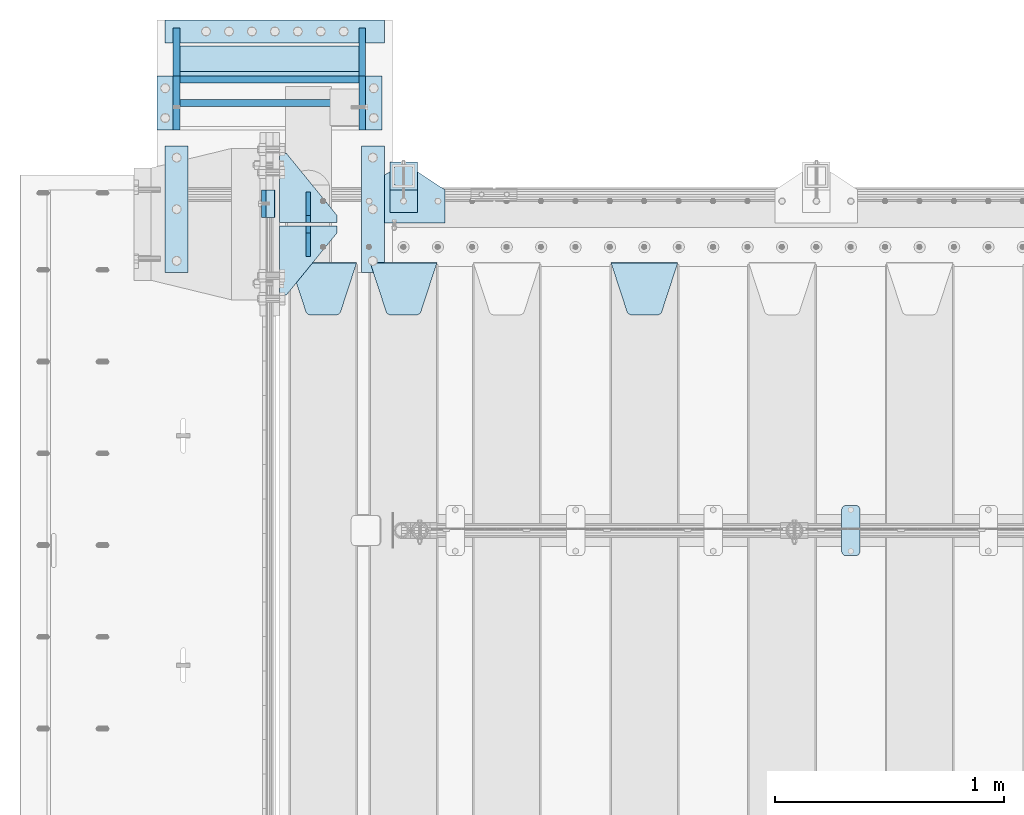
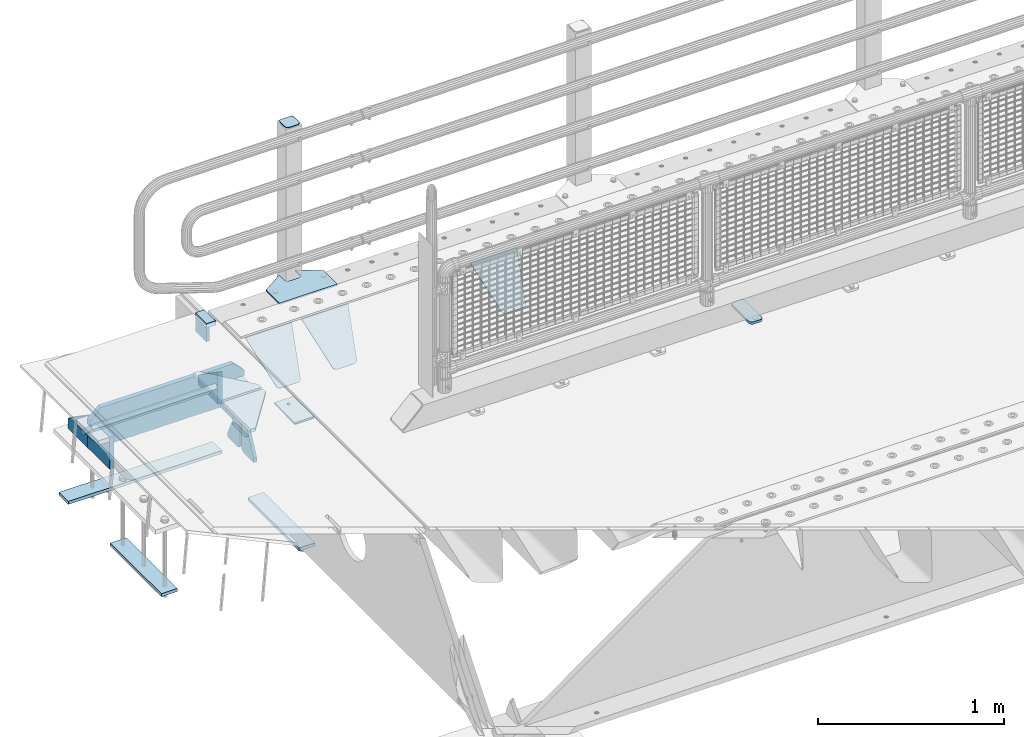
# One storey, part 200 of 242: 26 plates.
"""IFC2X3 building model written with IfcOpenShell, lengths in millimetres."""

import ifcopenshell
import ifcopenshell.guid

model = None  # the IFC model being written
_history = None  # IfcOwnerHistory: only IFC2X3 demands one
_inside = {}  # id of a spatial element -> (the spatial element, [elements in it])
_under = {}  # id of a project, library or spatial element -> (it, [spatial elements below it])
_declared = {}  # id of a project -> (the project, [libraries it declares])
_typed = {}  # id of a type object -> (the type object, [elements of that type])
_made_of = {}  # id of a material, layer set ... -> (it, [elements and type objects made of it])


def new_model(schema):
    """Start an empty IFC model of exactly this schema.

    Asked for "IFC4X3", IfcOpenShell would pick the latest addendum, in which some entities
    have other attributes; the version numbers below select the first issue.
    IFC2X3 requires an IfcOwnerHistory on every rooted entity: one is made here for all.
    """
    global model, _history
    if schema == "IFC4X3":
        model = ifcopenshell.file(schema_version=(4, 3, 0, 0))
    else:
        model = ifcopenshell.file(schema=schema)
    _inside.clear()
    _under.clear()
    _declared.clear()
    _typed.clear()
    _made_of.clear()
    _history = None
    if model.schema == "IFC2X3":
        org = make("IfcOrganization", Name="unknown")
        user = make(
            "IfcPersonAndOrganization",
            ThePerson=make("IfcPerson", FamilyName="unknown"),
            TheOrganization=org,
        )
        app = make(
            "IfcApplication",
            ApplicationDeveloper=org,
            Version="unknown",
            ApplicationFullName="unknown",
            ApplicationIdentifier="unknown",
        )
        _history = make(
            "IfcOwnerHistory",
            OwningUser=user,
            OwningApplication=app,
            ChangeAction="ADDED",
            CreationDate=0,
        )
    return model


def make(cls, **values):
    """One entity of the class cls with the attributes given. An attribute that is None is left unset."""
    return model.create_entity(
        cls, **{name: value for name, value in values.items() if value is not None}
    )


def rooted(cls, **values):
    """An entity with a GlobalId (a new one), such as an element, a storey or a relation."""
    return make(cls, GlobalId=ifcopenshell.guid.new(), OwnerHistory=_history, **values)


def si_unit(unit_type, name, prefix=None):
    """IfcSIUnit, for example si_unit("LENGTHUNIT", "METRE", prefix="MILLI")."""
    return make("IfcSIUnit", UnitType=unit_type, Prefix=prefix, Name=name)


def assignment(units):
    """IfcUnitAssignment: the units of a project."""
    return None if units is None else make("IfcUnitAssignment", Units=units)


def point(xyz):
    """IfcCartesianPoint."""
    return None if xyz is None else make("IfcCartesianPoint", Coordinates=xyz)


def direction(xyz):
    """IfcDirection."""
    return None if xyz is None else make("IfcDirection", DirectionRatios=xyz)


def frame(location, z_axis=None, x_axis=None):
    """IfcAxis2Placement3D, a coordinate frame: its origin and axes. An axis left out is left unset."""
    return make(
        "IfcAxis2Placement3D",
        Location=point(location),
        Axis=direction(z_axis),
        RefDirection=direction(x_axis),
    )


def origin_with_axes():
    """The frame at (0, 0, 0) with the z axis (0, 0, 1) and the x axis (1, 0, 0) written out."""
    return frame((0.0, 0.0, 0.0), z_axis=(0.0, 0.0, 1.0), x_axis=(1.0, 0.0, 0.0))


def place(relative_to, where):
    """IfcLocalPlacement: puts the frame where relative to a parent placement (None: the world)."""
    return make(
        "IfcLocalPlacement", PlacementRelTo=relative_to, RelativePlacement=where
    )


def context(
    kind, dimensions, precision=None, world=None, true_north=None, identifier=None
):
    """IfcGeometricRepresentationContext, for example the 3D "Model" context."""
    return make(
        "IfcGeometricRepresentationContext",
        ContextIdentifier=identifier,
        ContextType=kind,
        CoordinateSpaceDimension=dimensions,
        Precision=precision,
        WorldCoordinateSystem=world,
        TrueNorth=true_north,
    )


def subcontext(parent, identifier, kind, view, scale=None):
    """IfcGeometricRepresentationSubContext, for example "Body" below "Model"."""
    return make(
        "IfcGeometricRepresentationSubContext",
        ContextIdentifier=identifier,
        ContextType=kind,
        ParentContext=parent,
        TargetScale=scale,
        TargetView=view,
    )


def project(units=None, contexts=None):
    """IfcProject with its units and contexts."""
    return rooted(
        "IfcProject",
        Name="project",
        RepresentationContexts=contexts,
        UnitsInContext=assignment(units),
    )


def spatial(cls, under=None, at=None, **own):
    """A site, building, storey or space (cls), placed at a placement, below another one or the project."""
    s = rooted(cls, ObjectPlacement=at, **own)
    if under is not None:
        _under.setdefault(under.id(), (under, []))[1].append(s)
    return s


def faces_of(points, faces, orient=None, outer=None):
    """IfcFace entities. A face is a list of loops; a loop is a list of indices into points, from 0.

    orient and outer hold one flag for each loop. By default every Orientation is true, the
    first loop of a face is its IfcFaceOuterBound and the others are IfcFaceBound.
    """
    made = []
    for i, loops in enumerate(faces):
        bounds = []
        for j, loop in enumerate(loops):
            is_outer = j == 0 if outer is None else outer[i][j]
            bounds.append(
                make(
                    "IfcFaceOuterBound" if is_outer else "IfcFaceBound",
                    Bound=make("IfcPolyLoop", Polygon=[points[k] for k in loop]),
                    Orientation=True if orient is None else orient[i][j],
                )
            )
        made.append(make("IfcFace", Bounds=bounds))
    return made


def faceted_brep(points, faces, orient=None, outer=None, voids=None):
    """IfcFacetedBrep: a solid bounded by flat faces; with voids (closed shells), ...WithVoids."""
    shared = [point(p) for p in points]
    hull = make("IfcClosedShell", CfsFaces=faces_of(shared, faces, orient, outer))
    if voids is None:
        return make("IfcFacetedBrep", Outer=hull)
    return make(
        "IfcFacetedBrepWithVoids",
        Outer=hull,
        Voids=[
            make(cls, CfsFaces=faces_of(shared, fs, o, b)) for cls, fs, o, b in voids
        ],
    )


def shape(context_of_items, identifier, shape_type, items):
    """IfcShapeRepresentation: the items that make up one representation, for example the "Body"."""
    return make(
        "IfcShapeRepresentation",
        ContextOfItems=context_of_items,
        RepresentationIdentifier=identifier,
        RepresentationType=shape_type,
        Items=items,
    )


def material(Name=None, Category=None):
    """IfcMaterial."""
    return make("IfcMaterial", Name=Name, Category=Category)


def made_of(thing, what):
    """Note that an element or type object is made of a material, layer set ...; save() writes the relation."""
    if what is not None:
        _made_of.setdefault(what.id(), (what, []))[1].append(thing)
    return thing


def type_object(cls, material=None, **own):
    """A type object (cls), such as IfcWallType, which elements share."""
    return made_of(rooted(cls, **own), material)


def element(
    cls,
    number,
    at=None,
    inside=None,
    cuts=None,
    type_object=None,
    material=None,
    context=None,
    identifier="Body",
    shape_type=None,
    held_by="IfcProductDefinitionShape",
    body=None,
    shapes=None,
    **own,
):
    """One element of the class cls, such as IfcWall. Its Tag is "e" and its number.

    at: its placement. inside: the storey or other place that contains it. cuts: it is an
    opening in that element (IfcRelVoidsElement). A single representation is given by context,
    identifier, shape_type and body (its items); several are given by shapes. held_by: the class
    of the entity that holds the representations. save() writes the other relations.
    """
    e = rooted(cls, Tag="e%d" % number, ObjectPlacement=at, **own)
    if body is not None:
        shapes = [shape(context, identifier, shape_type, body)]
    if shapes is not None:
        e.Representation = make(held_by, Representations=shapes)
    if inside is not None:
        _inside.setdefault(inside.id(), (inside, []))[1].append(e)
    if cuts is not None:
        rooted(
            "IfcRelVoidsElement", RelatingBuildingElement=cuts, RelatedOpeningElement=e
        )
    if type_object is not None:
        _typed.setdefault(type_object.id(), (type_object, []))[1].append(e)
    return made_of(e, material)


def aggregate(whole, parts):
    """IfcRelAggregates: a whole, such as a stair, and the parts it consists of."""
    return rooted("IfcRelAggregates", RelatingObject=whole, RelatedObjects=parts)


def save(model, path):
    """Write the relations noted so far, then the file.

    IfcRelAggregates (storeys below a building ...), IfcRelContainedInSpatialStructure (elements
    in a storey), IfcRelDefinesByType, IfcRelAssociatesMaterial and IfcRelDeclares: one each for
    every whole, place, type object, material and project.
    """
    for whole, parts in _under.values():
        aggregate(whole, parts)
    for where, things in _inside.values():
        rooted(
            "IfcRelContainedInSpatialStructure",
            RelatedElements=things,
            RelatingStructure=where,
        )
    for kind, things in _typed.values():
        rooted("IfcRelDefinesByType", RelatedObjects=things, RelatingType=kind)
    for what, things in _made_of.values():
        rooted("IfcRelAssociatesMaterial", RelatedObjects=things, RelatingMaterial=what)
    for by, libraries in _declared.values():
        rooted("IfcRelDeclares", RelatingContext=by, RelatedDefinitions=libraries)
    model.write(path)


model = new_model("IFC2X3")

# Units and contexts
model_context = context("Model", 3, precision=1e-05, world=origin_with_axes())
body_context = subcontext(model_context, "Body", "Model", "MODEL_VIEW")
ifc_project = project(units=[si_unit("LENGTHUNIT", "METRE", prefix="MILLI"), si_unit("AREAUNIT", "SQUARE_METRE"), si_unit("VOLUMEUNIT", "CUBIC_METRE"), si_unit("MASSUNIT", "GRAM", prefix="KILO"), si_unit("TIMEUNIT", "SECOND"), si_unit("PLANEANGLEUNIT", "RADIAN"), si_unit("SOLIDANGLEUNIT", "STERADIAN"), si_unit("THERMODYNAMICTEMPERATUREUNIT", "DEGREE_CELSIUS"), si_unit("LUMINOUSINTENSITYUNIT", "LUMEN")], contexts=[model_context])

# Site, building, storey
site_placement = place(None, origin_with_axes())
site = spatial("IfcSite", under=ifc_project, at=site_placement, CompositionType="ELEMENT")
building_placement = place(site_placement, origin_with_axes())
building = spatial("IfcBuilding", under=site, at=building_placement, Name="Standard", CompositionType="ELEMENT")
storey_placement = place(building_placement, origin_with_axes())
storey = spatial("IfcBuildingStorey", under=building, at=storey_placement, Name="Undefined", CompositionType="ELEMENT", Elevation=0.0)

# Plates
ifc_material_1 = material()
plate_type_1 = type_object("IfcPlateType", PredefinedType="NOTDEFINED")
plate_1_placement = place(storey_placement, frame((-42460.0, -17910.0, -16.0000571414005), z_axis=(-1.0, 0.0, 0.0), x_axis=(0.0, 0.0, 1.0)))
element("IfcPlate", 1, at=plate_1_placement, inside=storey, type_object=plate_type_1, material=ifc_material_1, context=body_context, shape_type="Brep", body=[
    faceted_brep([(-1.77635683940025e-15, -60.0, 0.0), (2.49929144047201e-09, -60.0000000000073, 60.0), (2.49928966411517e-09, 59.9999999999964, 60.0), (-1.77635683940025e-15, 60.0, -7.27595761418343e-12), (25.0146748218828, -60.0000000000073, 60.0), (25.0146748218828, 59.9999999999927, 60.0), (26.5597449794466, -60.0000000000073, 59.7552873949098), (26.5597449794466, 59.9999999999964, 59.7552873949098), (27.9535758796897, -60.0000000000036, 59.0451032832789), (27.9535758796897, 59.9999999999964, 59.0451032832789), (29.0597323263517, -60.0000000000073, 57.9389640667287), (29.0597323263517, 59.9999999999927, 57.9389640667287), (29.7699381491534, -60.0000000000073, 56.5451442289705), (29.7699381491534, 59.9999999999927, 56.5451442289705), (30.0146748212763, -60.0000000000073, 55.0000778834001), (30.0146748212763, 59.9999999999927, 55.0000778834001), (30.0154536553013, -60.0000000000036, 5.00007788340736), (30.0154536553013, 59.9999999999964, 5.00007788340736), (29.7707554908505, -60.0000000000073, 3.45497428546514), (29.7707554908505, 59.9999999999927, 3.45497428546514), (29.0605660948355, -60.0000000000073, 2.06111154406972), (29.0605660948355, 59.9999999999927, 2.06111154406972), (27.9544051209123, -60.0000000000036, 0.954933339693525), (27.9544051209123, 59.9999999999964, 0.954933339693525), (26.5605534420796, -60.0000000000073, 0.244722232011554), (26.5605534420796, 59.9999999999927, 0.244722232011554), (25.0154536559091, -60.0000000000073, 7.27595761418343e-12), (25.0154536559091, 59.9999999999927, 7.27595761418343e-12)], [[[0, 1, 2, 3]], [[1, 4, 5, 2]], [[4, 6, 7, 5]], [[6, 8, 9, 7]], [[8, 10, 11, 9]], [[10, 12, 13, 11]], [[12, 14, 15, 13]], [[14, 16, 17, 15]], [[16, 18, 19, 17]], [[18, 20, 21, 19]], [[20, 22, 23, 21]], [[22, 24, 25, 23]], [[24, 26, 27, 25]], [[26, 0, 3, 27]], [[5, 7, 9, 11, 13, 15, 17, 19, 21, 23, 25, 27, 3, 2]], [[26, 24, 22, 20, 18, 16, 14, 12, 10, 8, 6, 4, 1, 0]]]),
])
ifc_material_2 = material(Name="STEEL/S355N")
plate_type_2 = type_object("IfcPlateType", PredefinedType="NOTDEFINED")
plate_2_placement = place(storey_placement, frame((-42510.0, -17849.9999144655, -105.984391680281), z_axis=(0.0, -1.0, 0.0), x_axis=(0.0, 0.0, 1.0)))
element("IfcPlate", 2, at=plate_2_placement, inside=storey, type_object=plate_type_2, material=ifc_material_2, context=body_context, shape_type="Brep", body=[
    faceted_brep([(0.0, -10.0, 0.0), (5.70725632087488e-07, -10.0, 120.0), (5.70725632087488e-07, 10.0, 120.0), (0.0, 10.0, 0.0), (89.9845046997066, -10.0, 120.000000000004), (89.9845046997066, 10.0, 120.000000000004), (89.9843902587891, -10.0, 6.91215973347425e-11), (89.9843902587891, 10.0, 6.91215973347425e-11)], [[[0, 1, 2, 3]], [[1, 4, 5, 2]], [[4, 6, 7, 5]], [[6, 0, 3, 7]], [[5, 7, 3, 2]], [[6, 4, 1, 0]]]),
])
ifc_material_3 = material(Name="STEEL/S355J2")
plate_type_3 = type_object("IfcPlateType", PredefinedType="NOTDEFINED")
plate_3_placement = place(storey_placement, frame((-39990.0, -19225.5, 21.0199999999977), z_axis=(1.0, 0.0, 0.0), x_axis=(0.0, -1.0, 0.0)))
element("IfcPlate", 3, at=plate_3_placement, inside=storey, type_object=plate_type_3, material=ifc_material_3, context=body_context, shape_type="Brep", body=[
    faceted_brep([(0.0, -7.0, 20.0), (0.0, -7.0, 60.0), (0.0, 7.0, 60.0), (0.0, 7.0, 20.0), (0.384294391937146, -7.0, 63.9018064403208), (0.384294391937146, 7.0, 63.9018064403208), (1.52240934977453, -7.0, 67.6536686473009), (1.52240934977453, 7.0, 67.6536686473009), (3.37060775395003, -7.0, 71.1114046603907), (3.37060775395003, 7.0, 71.1114046603907), (5.8578643762703, -7.0, 74.1421356237297), (5.8578643762703, 7.0, 74.1421356237297), (8.88859533960931, -7.0, 76.62939224605), (8.88859533960931, 7.0, 76.62939224605), (12.3463313526991, -7.0, 78.4775906502255), (12.3463313526991, 7.0, 78.4775906502255), (16.0981935596792, -7.0, 79.6157056080629), (16.0981935596792, 7.0, 79.6157056080629), (20.0, -7.0, 80.0), (20.0, 7.0, 80.0), (200.0, -7.0, 80.0), (200.0, 7.0, 80.0), (203.901806440321, -7.0, 79.6157056080629), (203.901806440321, 7.0, 79.6157056080629), (207.653668647301, -7.0, 78.4775906502255), (207.653668647301, 7.0, 78.4775906502255), (211.111404660391, -7.0, 76.62939224605), (211.111404660391, 7.0, 76.62939224605), (214.14213562373, -7.0, 74.1421356237297), (214.14213562373, 7.0, 74.1421356237297), (216.62939224605, -7.0, 71.1114046603907), (216.62939224605, 7.0, 71.1114046603907), (218.477590650225, -7.0, 67.6536686473009), (218.477590650225, 7.0, 67.6536686473009), (219.615705608063, -7.0, 63.9018064403208), (219.615705608063, 7.0, 63.9018064403208), (220.0, -7.0, 60.0), (220.0, 7.0, 60.0), (220.0, -7.0, 20.0), (220.0, 7.0, 20.0), (219.615705608063, -7.0, 16.0981935596792), (219.615705608063, 7.0, 16.0981935596792), (218.477590650225, -7.0, 12.3463313526991), (218.477590650225, 7.0, 12.3463313526991), (216.62939224605, -7.0, 8.88859533960931), (216.62939224605, 7.0, 8.88859533960931), (214.14213562373, -7.0, 5.8578643762703), (214.14213562373, 7.0, 5.8578643762703), (211.111404660391, -7.0, 3.37060775395003), (211.111404660391, 7.0, 3.37060775395003), (207.653668647301, -7.0, 1.52240934977453), (207.653668647301, 7.0, 1.52240934977453), (203.901806440321, -7.0, 0.384294391937146), (203.901806440321, 7.0, 0.384294391937146), (200.0, -7.0, 0.0), (200.0, 7.0, 0.0), (20.0, -7.0, 0.0), (20.0, 7.0, 0.0), (16.0981935596792, -7.0, 0.384294391937146), (16.0981935596792, 7.0, 0.384294391937146), (12.3463313526991, -7.0, 1.52240934977453), (12.3463313526991, 7.0, 1.52240934977453), (8.88859533960931, -7.0, 3.37060775395003), (8.88859533960931, 7.0, 3.37060775395003), (5.8578643762703, -7.0, 5.8578643762703), (5.8578643762703, 7.0, 5.8578643762703), (3.37060775395003, -7.0, 8.88859533960931), (3.37060775395003, 7.0, 8.88859533960931), (1.52240934977453, -7.0, 12.3463313526991), (1.52240934977453, 7.0, 12.3463313526991), (0.384294391937146, -7.0, 16.0981935596792), (0.384294391937146, 7.0, 16.0981935596792)], [[[0, 1, 2, 3]], [[1, 4, 5, 2]], [[4, 6, 7, 5]], [[6, 8, 9, 7]], [[8, 10, 11, 9]], [[10, 12, 13, 11]], [[12, 14, 15, 13]], [[14, 16, 17, 15]], [[16, 18, 19, 17]], [[18, 20, 21, 19]], [[20, 22, 23, 21]], [[22, 24, 25, 23]], [[24, 26, 27, 25]], [[26, 28, 29, 27]], [[28, 30, 31, 29]], [[30, 32, 33, 31]], [[32, 34, 35, 33]], [[34, 36, 37, 35]], [[36, 38, 39, 37]], [[38, 40, 41, 39]], [[40, 42, 43, 41]], [[42, 44, 45, 43]], [[44, 46, 47, 45]], [[46, 48, 49, 47]], [[48, 50, 51, 49]], [[50, 52, 53, 51]], [[52, 54, 55, 53]], [[54, 56, 57, 55]], [[56, 58, 59, 57]], [[58, 60, 61, 59]], [[60, 62, 63, 61]], [[62, 64, 65, 63]], [[64, 66, 67, 65]], [[66, 68, 69, 67]], [[68, 70, 71, 69]], [[70, 0, 3, 71]], [[5, 7, 9, 11, 13, 15, 17, 19, 21, 23, 25, 27, 29, 31, 33, 35, 37, 39, 41, 43, 45, 47, 49, 51, 53, 55, 57, 59, 61, 63, 65, 67, 69, 71, 3, 2]], [[70, 68, 66, 64, 62, 60, 58, 56, 54, 52, 50, 48, 46, 44, 42, 40, 38, 36, 34, 32, 30, 28, 26, 24, 22, 20, 18, 16, 14, 12, 10, 8, 6, 4, 1, 0]]]),
])
plate_type_4 = type_object("IfcPlateType", PredefinedType="NOTDEFINED")
plate_4_placement = place(storey_placement, frame((-42080.0, -17995.0, 5.00000000004911), z_axis=(0.0, 1.0, 0.0), x_axis=(1.0, 0.0, 0.0)))
element("IfcPlate", 4, at=plate_4_placement, inside=storey, type_object=plate_type_4, material=ifc_material_3, context=body_context, shape_type="Brep", body=[
    faceted_brep([(0.0, -5.0, 0.0), (2.31396552408114e-06, -5.0, 145.0), (2.31396552408114e-06, 5.0, 145.0), (0.0, 5.0, 0.0), (130.0, -5.0, 230.0), (130.0, 5.0, 230.0), (130.0, -5.0, 180.0), (130.0, 5.0, 180.0), (130.48036798992, -5.0, 175.122741949595), (130.48036798992, 5.0, 175.122741949595), (131.903011687216, -5.0, 170.432914190871), (131.903011687216, 5.0, 170.432914190871), (134.213259692435, -5.0, 166.110744174512), (134.213259692435, 5.0, 166.110744174512), (137.322330470335, -5.0, 162.322330470335), (137.322330470335, 5.0, 162.322330470335), (141.110744174512, -5.0, 159.213259692435), (141.110744174512, 5.0, 159.213259692435), (145.432914190871, -5.0, 156.903011687216), (145.432914190871, 5.0, 156.903011687216), (150.122741949595, -5.0, 155.48036798992), (150.122741949595, 5.0, 155.48036798992), (155.0, -5.0, 155.0), (155.0, 5.0, 155.0), (205.0, -5.0, 155.0), (205.0, 5.0, 155.0), (209.877258050405, -5.0, 155.48036798992), (209.877258050405, 5.0, 155.48036798992), (214.567085809129, -5.0, 156.903011687216), (214.567085809129, 5.0, 156.903011687216), (218.889255825488, -5.0, 159.213259692435), (218.889255825488, 5.0, 159.213259692435), (222.677669529665, -5.0, 162.322330470335), (222.677669529665, 5.0, 162.322330470335), (225.786740307565, -5.0, 166.110744174512), (225.786740307565, 5.0, 166.110744174512), (228.096988312784, -5.0, 170.432914190871), (228.096988312784, 5.0, 170.432914190871), (229.51963201008, -5.0, 175.122741949595), (229.51963201008, 5.0, 175.122741949595), (230.0, -5.0, 180.0), (230.0, 5.0, 180.0), (230.0, -5.0, 230.0), (230.0, 5.0, 230.0), (360.0, -5.0, 145.0), (360.0, 5.0, 145.0), (360.0, -5.0, -7.27595761418343e-12), (360.0, 5.0, -7.27595761418343e-12)], [[[0, 1, 2, 3]], [[1, 4, 5, 2]], [[4, 6, 7, 5]], [[6, 8, 9, 7]], [[8, 10, 11, 9]], [[10, 12, 13, 11]], [[12, 14, 15, 13]], [[14, 16, 17, 15]], [[16, 18, 19, 17]], [[18, 20, 21, 19]], [[20, 22, 23, 21]], [[22, 24, 25, 23]], [[24, 26, 27, 25]], [[26, 28, 29, 27]], [[28, 30, 31, 29]], [[30, 32, 33, 31]], [[32, 34, 35, 33]], [[34, 36, 37, 35]], [[36, 38, 39, 37]], [[38, 40, 41, 39]], [[40, 42, 43, 41]], [[42, 44, 45, 43]], [[44, 46, 47, 45]], [[46, 0, 3, 47]], [[5, 7, 9, 11, 13, 15, 17, 19, 21, 23, 25, 27, 29, 31, 33, 35, 37, 39, 41, 43, 45, 47, 3, 2]], [[46, 44, 42, 40, 38, 36, 34, 32, 30, 28, 26, 24, 22, 20, 18, 16, 14, 12, 10, 8, 6, 4, 1, 0]]]),
])
plate_type_5 = type_object("IfcPlateType", PredefinedType="NOTDEFINED")
plate_5_placement = place(storey_placement, frame((-41959.9999999999, -17949.9999999998, -850.000000000002), z_axis=(0.0, 1.0, 0.0), x_axis=(1.0, 0.0, 0.0)))
element("IfcPlate", 5, at=plate_5_placement, inside=storey, type_object=plate_type_5, material=ifc_material_3, context=body_context, shape_type="Brep", body=[
    faceted_brep([(66.3639610305399, -5.0, 163.636038969114), (66.3639610305399, 5.0, 163.636038969114), (59.9999999998618, 5.0, 160.999999999793), (59.9999999998618, -5.0, 160.999999999793), (53.6360389691836, 5.0, 163.636038969114), (53.6360389691836, -5.0, 163.636038969114), (50.9999999998618, 5.0, 169.999999999793), (50.9999999998618, -5.0, 169.999999999793), (53.6360389691836, 5.0, 176.363961030471), (53.6360389691836, -5.0, 176.363961030471), (59.9999999998618, 5.0, 178.999999999793), (59.9999999998618, -5.0, 178.999999999793), (66.3639610305399, 5.0, 176.363961030471), (66.3639610305399, -5.0, 176.363961030471), (68.9999999998618, 5.0, 169.999999999793), (68.9999999998618, -5.0, 169.999999999793), (120.0, -5.0, 0.0), (120.0, -5.0, 220.0), (0.0, -5.0, 220.0), (0.0, -5.0, 0.0), (0.0, 5.0, 0.0), (120.0, 5.0, 0.0), (120.0, 5.0, 220.0), (0.0, 5.0, 220.0)], [[[0, 1, 2, 3]], [[3, 2, 4, 5]], [[5, 4, 6, 7]], [[7, 6, 8, 9]], [[9, 8, 10, 11]], [[11, 10, 12, 13]], [[13, 12, 14, 15]], [[15, 14, 1, 0]], [[16, 17, 18, 19], [11, 13, 15, 0, 3, 5, 7, 9]], [[16, 19, 20, 21]], [[17, 16, 21, 22]], [[18, 17, 22, 23]], [[19, 18, 23, 20]], [[22, 21, 20, 23], [2, 1, 14, 12, 10, 8, 6, 4]]]),
])
plate_type_6 = type_object("IfcPlateType", PredefinedType="NOTDEFINED")
plate_6_placement = place(storey_placement, frame((-41855.9999999999, -17833.9999999998, 1012.50000000001), z_axis=(0.0, 1.0, 0.0), x_axis=(-1.0, 0.0, 0.0)))
element("IfcPlate", 6, at=plate_6_placement, inside=storey, type_object=plate_type_6, material=ifc_material_3, context=body_context, shape_type="Brep", body=[
    faceted_brep([(0.0, -2.5, 19.0), (0.0, -2.5, 69.0), (0.0, 2.5, 69.0), (0.0, 2.5, 19.0), (0.476369668544066, -2.5, 73.2278977451715), (0.476369668544066, 2.5, 73.2278977451715), (1.88159150985302, -2.5, 77.2437910432345), (1.88159150985302, 2.5, 77.2437910432345), (4.14520183310742, -2.5, 80.8463062353148), (4.14520183310742, 2.5, 80.8463062353148), (7.15369376468516, -2.5, 83.8547981668926), (7.15369376468516, 2.5, 83.8547981668926), (10.7562089567655, -2.5, 86.118408490147), (10.7562089567655, 2.5, 86.118408490147), (14.7721022548285, -2.5, 87.5236303314559), (14.7721022548285, 2.5, 87.5236303314559), (19.0, -2.5, 88.0), (19.0, 2.5, 88.0), (69.0, -2.5, 88.0), (69.0, 2.5, 88.0), (73.2278977451715, -2.5, 87.5236303314559), (73.2278977451715, 2.5, 87.5236303314559), (77.2437910432345, -2.5, 86.118408490147), (77.2437910432345, 2.5, 86.118408490147), (80.8463062353148, -2.5, 83.8547981668926), (80.8463062353148, 2.5, 83.8547981668926), (83.8547981668926, -2.5, 80.8463062353148), (83.8547981668926, 2.5, 80.8463062353148), (86.118408490147, -2.5, 77.2437910432345), (86.118408490147, 2.5, 77.2437910432345), (87.5236303314559, -2.5, 73.2278977451715), (87.5236303314559, 2.5, 73.2278977451715), (88.0, -2.5, 69.0), (88.0, 2.5, 69.0), (88.0, -2.5, 19.0), (88.0, 2.5, 19.0), (87.5236303314559, -2.5, 14.7721022548285), (87.5236303314559, 2.5, 14.7721022548285), (86.118408490147, -2.5, 10.7562089567655), (86.118408490147, 2.5, 10.7562089567655), (83.8547981668926, -2.5, 7.15369376468516), (83.8547981668926, 2.5, 7.15369376468516), (80.8463062353148, -2.5, 4.14520183310742), (80.8463062353148, 2.5, 4.14520183310742), (77.2437910432345, -2.5, 1.88159150985302), (77.2437910432345, 2.5, 1.88159150985302), (73.2278977451715, -2.5, 0.476369668544066), (73.2278977451715, 2.5, 0.476369668544066), (69.0, -2.5, 0.0), (69.0, 2.5, 0.0), (19.0, -2.5, 0.0), (19.0, 2.5, 0.0), (14.7721022548285, -2.5, 0.476369668544066), (14.7721022548285, 2.5, 0.476369668544066), (10.7562089567655, -2.5, 1.88159150985302), (10.7562089567655, 2.5, 1.88159150985302), (7.15369376468516, -2.5, 4.14520183310742), (7.15369376468516, 2.5, 4.14520183310742), (4.14520183310742, -2.5, 7.15369376468516), (4.14520183310742, 2.5, 7.15369376468516), (1.88159150985302, -2.5, 10.7562089567655), (1.88159150985302, 2.5, 10.7562089567655), (0.476369668544066, -2.5, 14.7721022548285), (0.476369668544066, 2.5, 14.7721022548285)], [[[0, 1, 2, 3]], [[1, 4, 5, 2]], [[4, 6, 7, 5]], [[6, 8, 9, 7]], [[8, 10, 11, 9]], [[10, 12, 13, 11]], [[12, 14, 15, 13]], [[14, 16, 17, 15]], [[16, 18, 19, 17]], [[18, 20, 21, 19]], [[20, 22, 23, 21]], [[22, 24, 25, 23]], [[24, 26, 27, 25]], [[26, 28, 29, 27]], [[28, 30, 31, 29]], [[30, 32, 33, 31]], [[32, 34, 35, 33]], [[34, 36, 37, 35]], [[36, 38, 39, 37]], [[38, 40, 41, 39]], [[40, 42, 43, 41]], [[42, 44, 45, 43]], [[44, 46, 47, 45]], [[46, 48, 49, 47]], [[48, 50, 51, 49]], [[50, 52, 53, 51]], [[52, 54, 55, 53]], [[54, 56, 57, 55]], [[56, 58, 59, 57]], [[58, 60, 61, 59]], [[60, 62, 63, 61]], [[62, 0, 3, 63]], [[5, 7, 9, 11, 13, 15, 17, 19, 21, 23, 25, 27, 29, 31, 33, 35, 37, 39, 41, 43, 45, 47, 49, 51, 53, 55, 57, 59, 61, 63, 3, 2]], [[62, 60, 58, 56, 54, 52, 50, 48, 46, 44, 42, 40, 38, 36, 34, 32, 30, 28, 26, 24, 22, 20, 18, 16, 14, 12, 10, 8, 6, 4, 1, 0]]]),
])
plate_type_7 = type_object("IfcPlateType", PredefinedType="NOTDEFINED")
plate_7_placement = place(storey_placement, frame((-41959.9999999999, -17949.9999999998, -857.500000000002), z_axis=(0.0, 1.0, 0.0), x_axis=(1.0, 0.0, 0.0)))
element("IfcPlate", 7, at=plate_7_placement, inside=storey, type_object=plate_type_7, material=ifc_material_3, context=body_context, shape_type="Brep", body=[
    faceted_brep([(0.0, -2.5, 0.0), (0.0, -2.5, 100.0), (0.0, 2.5, 100.0), (0.0, 2.5, 0.0), (120.0, -2.5, 100.0), (120.0, 2.5, 100.0), (120.0, -2.5, 0.0), (120.0, 2.5, 0.0)], [[[0, 1, 2, 3]], [[1, 4, 5, 2]], [[4, 6, 7, 5]], [[6, 0, 3, 7]], [[5, 7, 3, 2]], [[6, 4, 1, 0]]]),
])
plate_type_8 = type_object("IfcPlateType", PredefinedType="NOTDEFINED")
plate_8_placement = place(storey_placement, frame((-40995.0, -18168.2322330441, -1.76776695296576), z_axis=(0.0, -0.707106781186547, -0.707106781186548), x_axis=(1.0, 0.0, 0.0)))
element("IfcPlate", 8, at=plate_8_placement, inside=storey, type_object=plate_type_8, material=ifc_material_2, context=body_context, shape_type="Brep", body=[
    faceted_brep([(0.0, -2.5, 0.0), (69.345504679477, -2.50000000000182, 300.171731424829), (69.345504679477, 2.5, 300.171731424829), (0.0, 2.5, 0.0), (70.9274061199576, -2.5, 304.897442415398), (70.9274061199576, 2.5, 304.897442415398), (73.3818627772307, -2.5, 309.234538108525), (73.3818627772307, 2.50000000000182, 309.234538108529), (76.6187032999551, -2.5, 313.023683126101), (76.6187032999551, 2.50000000000182, 313.023683126103), (80.5190132704993, -2.5, 316.12567259537), (80.5190132704993, 2.5, 316.12567259537), (84.9395038596849, -2.5, 318.426546230474), (84.9395038596849, 2.50000000000182, 318.426546230476), (89.7177759439219, -2.49999999999818, 319.841774983273), (89.7177759439219, 2.50000000000182, 319.841774983273), (94.678286292652, -2.5, 320.319366455076), (94.678286292652, 2.5, 320.319366455076), (195.321713707348, -2.5, 320.319366455076), (195.321713707348, 2.5, 320.319366455076), (200.282224056078, -2.5, 319.841774983272), (200.282224056078, 2.50000000000182, 319.841774983273), (205.060496140315, -2.5, 318.426546230474), (205.060496140315, 2.49999999999818, 318.426546230474), (209.480986729501, -2.49999999999818, 316.12567259537), (209.480986729501, 2.5, 316.12567259537), (213.381296700045, -2.5, 313.023683126101), (213.381296700045, 2.49999999999818, 313.023683126101), (216.618137222769, -2.5, 309.234538108525), (216.618137222769, 2.5, 309.234538108523), (219.072593880042, -2.49999999999818, 304.897442415398), (219.072593880042, 2.50000000000182, 304.897442415398), (220.654495320523, -2.50000000000182, 300.171731424829), (220.654495320523, 2.5, 300.171731424829), (290.0, -2.5, 0.0), (290.0, 2.5, -1.81898940354586e-12)], [[[0, 1, 2, 3]], [[1, 4, 5, 2]], [[4, 6, 7, 5]], [[6, 8, 9, 7]], [[8, 10, 11, 9]], [[10, 12, 13, 11]], [[12, 14, 15, 13]], [[14, 16, 17, 15]], [[16, 18, 19, 17]], [[18, 20, 21, 19]], [[20, 22, 23, 21]], [[22, 24, 25, 23]], [[24, 26, 27, 25]], [[26, 28, 29, 27]], [[28, 30, 31, 29]], [[30, 32, 33, 31]], [[32, 34, 35, 33]], [[34, 0, 3, 35]], [[5, 7, 9, 11, 13, 15, 17, 19, 21, 23, 25, 27, 29, 31, 33, 35, 3, 2]], [[34, 32, 30, 28, 26, 24, 22, 20, 18, 16, 14, 12, 10, 8, 6, 4, 1, 0]]]),
])
plate_9_placement = place(storey_placement, frame((-42045.0, -18168.2322330441, -1.76776695296576), z_axis=(0.0, -0.707106781186547, -0.707106781186548), x_axis=(1.0, 0.0, 0.0)))
element("IfcPlate", 9, at=plate_9_placement, inside=storey, type_object=plate_type_8, material=ifc_material_2, context=body_context, shape_type="Brep", body=[
    faceted_brep([(0.0, -2.5, 0.0), (69.345504679477, -2.50000000000182, 300.171731424829), (69.345504679477, 2.5, 300.171731424829), (0.0, 2.5, 0.0), (70.9274061199576, -2.5, 304.897442415398), (70.9274061199576, 2.5, 304.897442415398), (73.3818627772307, -2.5, 309.234538108525), (73.3818627772307, 2.50000000000182, 309.234538108529), (76.6187032999551, -2.5, 313.023683126101), (76.6187032999551, 2.50000000000182, 313.023683126103), (80.5190132704993, -2.5, 316.12567259537), (80.5190132704993, 2.5, 316.12567259537), (84.9395038596849, -2.5, 318.426546230474), (84.9395038596849, 2.50000000000182, 318.426546230476), (89.7177759439219, -2.49999999999818, 319.841774983273), (89.7177759439219, 2.50000000000182, 319.841774983273), (94.678286292652, -2.5, 320.319366455076), (94.678286292652, 2.5, 320.319366455076), (195.321713707348, -2.5, 320.319366455076), (195.321713707348, 2.5, 320.319366455076), (200.282224056078, -2.5, 319.841774983272), (200.282224056078, 2.50000000000182, 319.841774983273), (205.060496140315, -2.5, 318.426546230474), (205.060496140315, 2.49999999999818, 318.426546230474), (209.480986729501, -2.49999999999818, 316.12567259537), (209.480986729501, 2.5, 316.12567259537), (213.381296700045, -2.5, 313.023683126101), (213.381296700045, 2.49999999999818, 313.023683126101), (216.618137222769, -2.5, 309.234538108525), (216.618137222769, 2.5, 309.234538108523), (219.072593880042, -2.49999999999818, 304.897442415398), (219.072593880042, 2.50000000000182, 304.897442415398), (220.654495320523, -2.50000000000182, 300.171731424829), (220.654495320523, 2.5, 300.171731424829), (290.0, -2.5, 0.0), (290.0, 2.5, -1.81898940354586e-12)], [[[0, 1, 2, 3]], [[1, 4, 5, 2]], [[4, 6, 7, 5]], [[6, 8, 9, 7]], [[8, 10, 11, 9]], [[10, 12, 13, 11]], [[12, 14, 15, 13]], [[14, 16, 17, 15]], [[16, 18, 19, 17]], [[18, 20, 21, 19]], [[20, 22, 23, 21]], [[22, 24, 25, 23]], [[24, 26, 27, 25]], [[26, 28, 29, 27]], [[28, 30, 31, 29]], [[30, 32, 33, 31]], [[32, 34, 35, 33]], [[34, 0, 3, 35]], [[5, 7, 9, 11, 13, 15, 17, 19, 21, 23, 25, 27, 29, 31, 33, 35, 3, 2]], [[34, 32, 30, 28, 26, 24, 22, 20, 18, 16, 14, 12, 10, 8, 6, 4, 1, 0]]]),
])
plate_10_placement = place(storey_placement, frame((-42395.0, -18168.2322330441, -1.76776695296576), z_axis=(0.0, -0.707106781186547, -0.707106781186548), x_axis=(1.0, 0.0, 0.0)))
element("IfcPlate", 10, at=plate_10_placement, inside=storey, type_object=plate_type_8, material=ifc_material_2, context=body_context, shape_type="Brep", body=[
    faceted_brep([(0.0, -2.5, 0.0), (69.345504679477, -2.50000000000182, 300.171731424829), (69.345504679477, 2.5, 300.171731424829), (0.0, 2.5, 0.0), (70.9274061199576, -2.5, 304.897442415398), (70.9274061199576, 2.5, 304.897442415398), (73.3818627772307, -2.5, 309.234538108525), (73.3818627772307, 2.50000000000182, 309.234538108529), (76.6187032999551, -2.5, 313.023683126101), (76.6187032999551, 2.50000000000182, 313.023683126103), (80.5190132704993, -2.5, 316.12567259537), (80.5190132704993, 2.5, 316.12567259537), (84.9395038596849, -2.5, 318.426546230474), (84.9395038596849, 2.50000000000182, 318.426546230476), (89.7177759439219, -2.49999999999818, 319.841774983273), (89.7177759439219, 2.50000000000182, 319.841774983273), (94.678286292652, -2.5, 320.319366455076), (94.678286292652, 2.5, 320.319366455076), (195.321713707348, -2.5, 320.319366455076), (195.321713707348, 2.5, 320.319366455076), (200.282224056078, -2.5, 319.841774983272), (200.282224056078, 2.50000000000182, 319.841774983273), (205.060496140315, -2.5, 318.426546230474), (205.060496140315, 2.49999999999818, 318.426546230474), (209.480986729501, -2.49999999999818, 316.12567259537), (209.480986729501, 2.5, 316.12567259537), (213.381296700045, -2.5, 313.023683126101), (213.381296700045, 2.49999999999818, 313.023683126101), (216.618137222769, -2.5, 309.234538108525), (216.618137222769, 2.5, 309.234538108523), (219.072593880042, -2.49999999999818, 304.897442415398), (219.072593880042, 2.50000000000182, 304.897442415398), (220.654495320523, -2.50000000000182, 300.171731424829), (220.654495320523, 2.5, 300.171731424829), (290.0, -2.5, 0.0), (290.0, 2.5, -1.81898940354586e-12)], [[[0, 1, 2, 3]], [[1, 4, 5, 2]], [[4, 6, 7, 5]], [[6, 8, 9, 7]], [[8, 10, 11, 9]], [[10, 12, 13, 11]], [[12, 14, 15, 13]], [[14, 16, 17, 15]], [[16, 18, 19, 17]], [[18, 20, 21, 19]], [[20, 22, 23, 21]], [[22, 24, 25, 23]], [[24, 26, 27, 25]], [[26, 28, 29, 27]], [[28, 30, 31, 29]], [[30, 32, 33, 31]], [[32, 34, 35, 33]], [[34, 0, 3, 35]], [[5, 7, 9, 11, 13, 15, 17, 19, 21, 23, 25, 27, 29, 31, 33, 35, 3, 2]], [[34, 32, 30, 28, 26, 24, 22, 20, 18, 16, 14, 12, 10, 8, 6, 4, 1, 0]]]),
])
plate_type_9 = type_object("IfcPlateType", PredefinedType="NOTDEFINED")
for number, where, z_axis, x_axis in (
    (11, (-42190.0, -17992.0, -515.0), (0.0, 1.0, 0.0), (-1.0, 0.0, 0.0)),
    (12, (-42190.0, -18008.0, -515.0), (0.0, -1.0, 0.0), (-1.0, 0.0, 0.0)),
):
    element("IfcPlate", number, at=place(storey_placement, frame(where, z_axis=z_axis, x_axis=x_axis)), inside=storey, type_object=plate_type_9, material=ifc_material_2, context=body_context, shape_type="Brep", body=[
        faceted_brep([(0.0, -10.0, 0.0), (0.0, -10.0, 30.0), (0.0, 10.0, 30.0), (0.0, 10.0, 0.0), (220.0, -10.0, 300.0), (220.0, 10.0, 300.0), (250.0, -10.0, 300.0), (250.0, 10.0, 300.0), (250.0, -10.0, 0.0), (250.0, 10.0, 0.0)], [[[0, 1, 2, 3]], [[1, 4, 5, 2]], [[4, 6, 7, 5]], [[6, 8, 9, 7]], [[8, 0, 3, 9]], [[5, 7, 9, 3, 2]], [[8, 6, 4, 1, 0]]]),
    ])
plate_type_10 = type_object("IfcPlateType", PredefinedType="NOTDEFINED")
for number, where, z_axis, x_axis in (
    (13, (-42315.0, -17860.0, -865.0), (0.0, 0.0, 1.0), (0.0, -1.0, 0.0)),
    (14, (-42315.0, -18140.0, -865.0), (0.0, 0.0, 1.0), (0.0, 1.0, 0.0)),
):
    element("IfcPlate", number, at=place(storey_placement, frame(where, z_axis=z_axis, x_axis=x_axis)), inside=storey, type_object=plate_type_10, material=ifc_material_2, context=body_context, shape_type="Brep", body=[
        faceted_brep([(0.0, -10.0, 0.0), (0.0, -10.0, 30.0), (0.0, 10.0, 30.0), (0.0, 10.0, 0.0), (102.0, -10.0, 250.0), (102.0, 10.0, 250.0), (132.0, -10.0, 250.0), (132.0, 10.0, 250.0), (132.0, -10.0, 30.0), (132.0, 10.0, 30.0), (131.544232590368, -10.0, 24.790554669992), (131.544232590368, 10.0, 24.790554669992), (130.190778623579, -10.0, 19.7393957002299), (130.190778623579, 10.0, 19.7393957002299), (127.980762113533, -10.0, 15.0), (127.980762113533, 10.0, 15.0), (124.98133329357, -10.0, 10.7163717094038), (124.98133329357, 10.0, 10.7163717094038), (121.283628290596, -10.0, 7.01866670643062), (121.283628290596, 10.0, 7.01866670643062), (117.0, -10.0, 4.01923788646684), (117.0, 10.0, 4.01923788646684), (112.260604299769, -10.0, 1.80922137642278), (112.260604299769, 10.0, 1.80922137642278), (107.209445330009, -10.0, 0.455767409633722), (107.209445330009, 10.0, 0.455767409633722), (102.0, -10.0, 0.0), (102.0, 10.0, 0.0)], [[[0, 1, 2, 3]], [[1, 4, 5, 2]], [[4, 6, 7, 5]], [[6, 8, 9, 7]], [[8, 10, 11, 9]], [[10, 12, 13, 11]], [[12, 14, 15, 13]], [[14, 16, 17, 15]], [[16, 18, 19, 17]], [[18, 20, 21, 19]], [[20, 22, 23, 21]], [[22, 24, 25, 23]], [[24, 26, 27, 25]], [[26, 0, 3, 27]], [[5, 7, 9, 11, 13, 15, 17, 19, 21, 23, 25, 27, 3, 2]], [[26, 24, 22, 20, 18, 16, 14, 12, 10, 8, 6, 4, 1, 0]]]),
    ])
plate_type_11 = type_object("IfcPlateType", PredefinedType="NOTDEFINED")
plate_11_placement = place(storey_placement, frame((-42095.0000000015, -17234.64286525, -1027.14966545659), z_axis=(-1.0, 0.0, 0.0), x_axis=(0.0, -0.723355636225728, 0.690475650215467)))
element("IfcPlate", 15, at=plate_11_placement, inside=storey, type_object=plate_type_11, material=ifc_material_2, context=body_context, shape_type="Brep", body=[
    faceted_brep([(0.0, -15.0, 0.0), (0.0, -15.0, 779.0), (1.81898940354586e-12, 14.9999999999982, 779.0), (0.0, 15.0, 0.0), (152.069061279297, -15.0000000000018, 779.0), (152.069061279297, 14.9999999999982, 779.0), (152.069061279297, -15.0000000000018, 0.0), (152.069061279297, 14.9999999999982, 0.0)], [[[0, 1, 2, 3]], [[1, 4, 5, 2]], [[4, 6, 7, 5]], [[6, 0, 3, 7]], [[5, 7, 3, 2]], [[6, 4, 1, 0]]]),
])
plate_type_12 = type_object("IfcPlateType", PredefinedType="NOTDEFINED")
for number, where, z_axis, x_axis in (
    (16, (-42939.0, -17660.0000014664, -1478.0), (0.0, -1.0, 0.0), (1.0, 0.0, 0.0)),
    (17, (-42084.0, -17660.0000014695, -1478.0), (0.0, -1.0, 0.0), (1.0, 0.0, 0.0)),
):
    element("IfcPlate", number, at=place(storey_placement, frame(where, z_axis=z_axis, x_axis=x_axis)), inside=storey, type_object=plate_type_12, material=ifc_material_2, context=body_context, shape_type="Brep", body=[
        faceted_brep([(0.0, -10.0, 0.0), (1.00942997960374e-06, -10.0, 550.0), (1.00942997960374e-06, 10.0, 550.0), (0.0, 10.0, 0.0), (100.0, -10.0, 550.0), (100.0, 10.0, 550.0), (100.0, -10.0, 0.0), (100.0, 10.0, 0.0)], [[[0, 1, 2, 3]], [[1, 4, 5, 2]], [[4, 6, 7, 5]], [[6, 0, 3, 7]], [[5, 7, 3, 2]], [[6, 4, 1, 0]]]),
    ])
plate_12_placement = place(storey_placement, frame((-42939.000000002, -17110.0000014664, -1478.0), z_axis=(0.0, -1.0, 0.0), x_axis=(1.0, 0.0, 0.0)))
element("IfcPlate", 18, at=plate_12_placement, inside=storey, type_object=plate_type_12, material=ifc_material_2, context=body_context, shape_type="Brep", body=[
    faceted_brep([(0.0, -10.0, 0.0), (0.0, -10.0, 100.0), (0.0, 10.0, 100.0), (0.0, 10.0, 0.0), (955.0, -10.0, 100.0), (955.0, 10.0, 100.0), (955.0, -10.0, 0.0), (955.0, 10.0, 0.0)], [[[0, 1, 2, 3]], [[1, 4, 5, 2]], [[4, 6, 7, 5]], [[6, 0, 3, 7]], [[5, 7, 3, 2]], [[6, 4, 1, 0]]]),
])
plate_type_13 = type_object("IfcPlateType", PredefinedType="NOTDEFINED")
for number, where, z_axis, x_axis in (
    (19, (-42080.0000000019, -17145.0000000033, -1038.0), (0.0, 0.0, 1.0), (0.0, -1.0, 0.0)),
    (20, (-42889.0000000019, -17145.0000000003, -1038.0), (0.0, 0.0, 1.0), (0.0, -1.0, 0.0)),
):
    element("IfcPlate", number, at=place(storey_placement, frame(where, z_axis=z_axis, x_axis=x_axis)), inside=storey, type_object=plate_type_13, material=ifc_material_2, context=body_context, shape_type="Brep", body=[
        faceted_brep([(0.0, -15.0, 0.0), (0.0, -15.0, 66.0), (0.0, 15.0, 66.0), (0.0, 15.0, 0.0), (210.0, -15.0, 210.0), (210.0, 15.0, 210.0), (210.0, -15.0, 0.0), (210.0, 15.0, 0.0)], [[[0, 1, 2, 3]], [[1, 4, 5, 2]], [[4, 6, 7, 5]], [[6, 0, 3, 7]], [[5, 7, 3, 2]], [[6, 4, 1, 0]]]),
    ])
plate_13_placement = place(storey_placement, frame((-42080.0000000002, -17590.0000000033, -828.000000000005), z_axis=(0.0, 0.0, -1.0), x_axis=(0.0, 1.0, 0.0)))
element("IfcPlate", 21, at=plate_13_placement, inside=storey, type_object=plate_type_13, material=ifc_material_2, context=body_context, shape_type="Brep", body=[
    faceted_brep([(0.0, -15.0, 0.0), (0.0, -15.0, 210.0), (0.0, 15.0, 210.0), (0.0, 15.0, 0.0), (235.0, -15.0, 210.0), (235.0, 15.0, 210.0), (235.0, -15.0, 0.0), (235.0, 15.0, 0.0)], [[[0, 1, 2, 3]], [[1, 4, 5, 2]], [[4, 6, 7, 5]], [[6, 0, 3, 7]], [[5, 7, 3, 2]], [[6, 4, 1, 0]]]),
])
plate_14_placement = place(storey_placement, frame((-42874.000000001, -17370.0000000004, -1038.0), z_axis=(1.0, 0.0, 0.0), x_axis=(0.0, 0.0, 1.0)))
element("IfcPlate", 22, at=plate_14_placement, inside=storey, type_object=plate_type_13, material=ifc_material_2, context=body_context, shape_type="Brep", body=[
    faceted_brep([(0.0, -15.0, 0.0), (0.0, -15.0, 779.0), (1.81898940354586e-12, 14.9999999999982, 779.0), (0.0, 15.0, 0.0), (210.0, -15.0, 779.0), (210.0, 15.0, 779.0), (210.0, -15.0, 0.0), (210.0, 15.0, 0.0)], [[[0, 1, 2, 3]], [[1, 4, 5, 2]], [[4, 6, 7, 5]], [[6, 0, 3, 7]], [[5, 7, 3, 2]], [[6, 4, 1, 0]]]),
])
plate_15_placement = place(storey_placement, frame((-42889.0000000002, -17590.0000000003, -828.000000000004), z_axis=(0.0, 0.0, -1.0), x_axis=(0.0, 1.0, 0.0)))
element("IfcPlate", 23, at=plate_15_placement, inside=storey, type_object=plate_type_13, material=ifc_material_2, context=body_context, shape_type="Brep", body=[
    faceted_brep([(0.0, -15.0, 0.0), (0.0, -15.0, 210.0), (0.0, 15.0, 210.0), (0.0, 15.0, 0.0), (235.0, -15.0, 210.0), (235.0, 15.0, 210.0), (235.0, -15.0, 0.0), (235.0, 15.0, 0.0)], [[[0, 1, 2, 3]], [[1, 4, 5, 2]], [[4, 6, 7, 5]], [[6, 0, 3, 7]], [[5, 7, 3, 2]], [[6, 4, 1, 0]]]),
])
plate_type_14 = type_object("IfcPlateType", PredefinedType="NOTDEFINED")
plate_16_placement = place(storey_placement, frame((-42964.0000000007, -17472.5, -798.000000000004), z_axis=(0.0, 0.0, 1.0), x_axis=(1.0, 0.0, 0.0)))
element("IfcPlate", 24, at=plate_16_placement, inside=storey, type_object=plate_type_14, material=ifc_material_2, context=body_context, shape_type="Brep", body=[
    faceted_brep([(0.0, -15.0, 0.0), (0.0, -15.0, 33.0), (0.0, 15.0, 33.0), (0.0, 15.0, 0.0), (67.0, -15.0, 100.0), (67.0, 15.0, 100.0), (892.0, -15.0, 100.0), (892.0, 15.0, 100.0), (959.0, -15.0, 33.0), (959.0, 15.0, 33.0), (959.0, -15.0, 0.0), (959.0, 15.0, 0.0)], [[[0, 1, 2, 3]], [[1, 4, 5, 2]], [[4, 6, 7, 5]], [[6, 8, 9, 7]], [[8, 10, 11, 9]], [[10, 0, 3, 11]], [[5, 7, 9, 11, 3, 2]], [[10, 8, 6, 4, 1, 0]]]),
])
plate_type_15 = type_object("IfcPlateType", PredefinedType="NOTDEFINED")
for number, where, z_axis, x_axis in (
    (25, (-42065.0000000011, -17355.0000000033, -843.000000000004), (1.0, 0.0, 0.0), (0.0, -1.0, 0.0)),
    (26, (-42974.0000000011, -17355.0, -843.000000000004), (1.0, 0.0, 0.0), (0.0, -1.0, 0.0)),
):
    element("IfcPlate", number, at=place(storey_placement, frame(where, z_axis=z_axis, x_axis=x_axis)), inside=storey, type_object=plate_type_15, material=ifc_material_2, context=body_context, shape_type="Brep", body=[
        faceted_brep([(0.0, -15.0, 0.0), (0.0, -15.0, 70.0), (0.0, 15.0, 70.0), (0.0, 15.0, 0.0), (235.0, -15.0, 70.0), (235.0, 15.0, 70.0), (235.0, -15.0, 0.0), (235.0, 15.0, 0.0)], [[[0, 1, 2, 3]], [[1, 4, 5, 2]], [[4, 6, 7, 5]], [[6, 0, 3, 7]], [[5, 7, 3, 2]], [[6, 4, 1, 0]]]),
    ])

save(model, "model.ifc")
